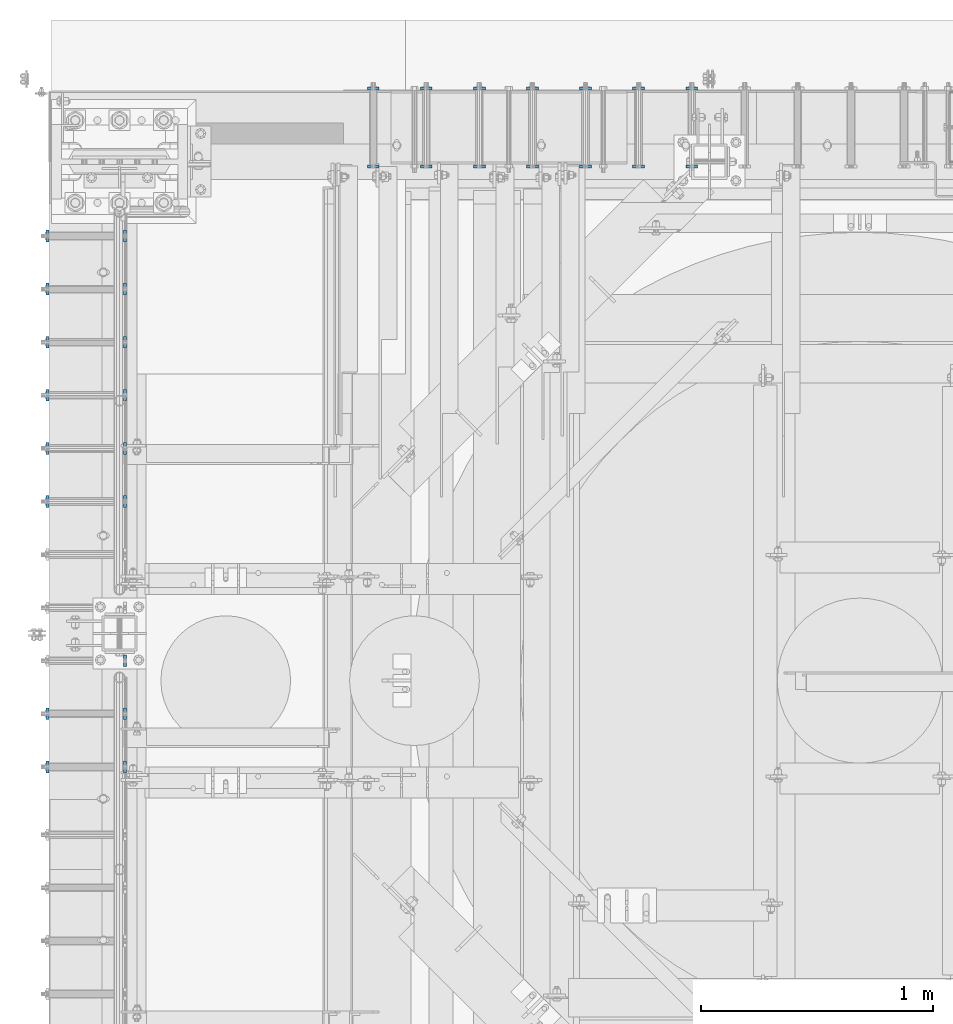
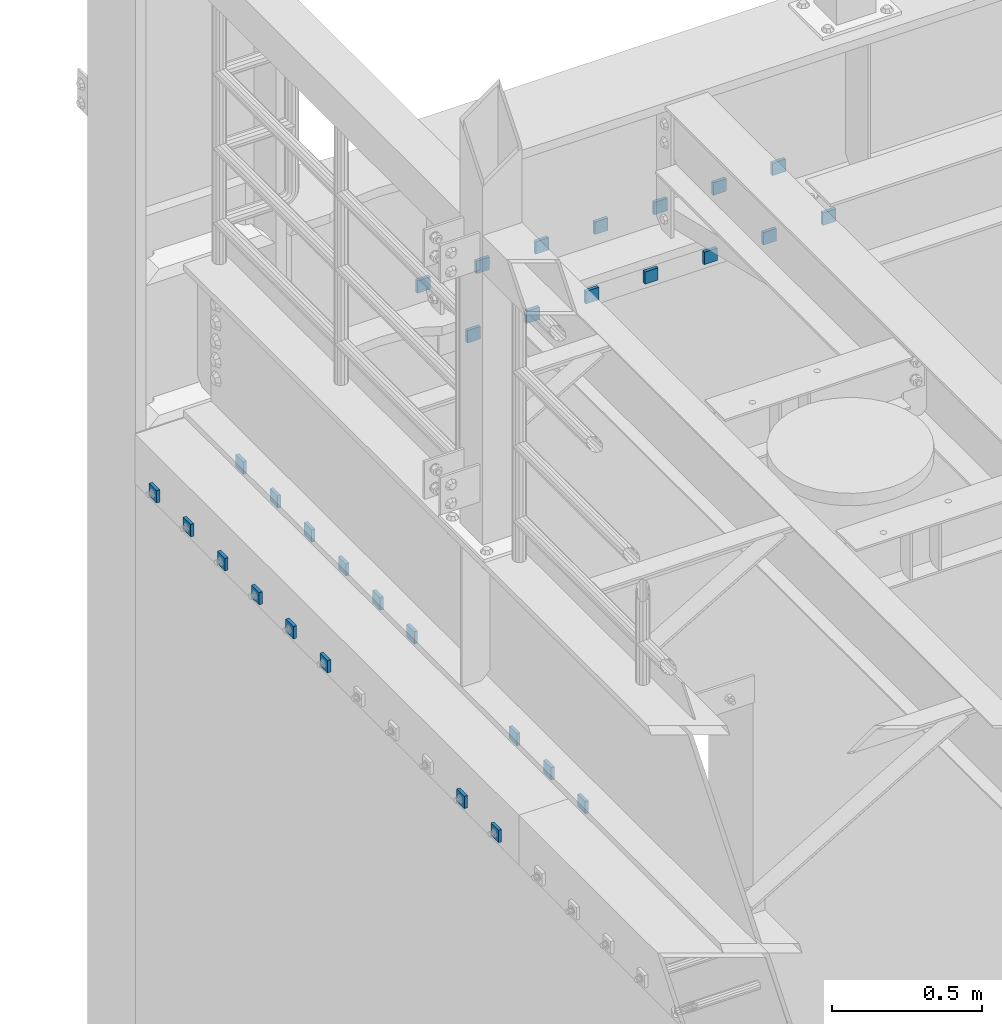
# One storey, part 1843 of 1876: 31 plates, 31 elements without a shape of their own.
"""IFC2X3 building model written with IfcOpenShell, lengths in millimetres."""

from ifc_helpers import new_model, si_unit, frame, origin_with_axes, place, context, subcontext, project, spatial, faceted_brep, material, type_object, element, aggregate, save


model = new_model("IFC2X3")

# Units and contexts
model_context = context("Model", 3, precision=1e-05, world=origin_with_axes())
body_context = subcontext(model_context, "Body", "Model", "MODEL_VIEW")
ifc_project = project(units=[si_unit("LENGTHUNIT", "METRE", prefix="MILLI"), si_unit("AREAUNIT", "SQUARE_METRE"), si_unit("VOLUMEUNIT", "CUBIC_METRE"), si_unit("MASSUNIT", "GRAM", prefix="KILO"), si_unit("TIMEUNIT", "SECOND"), si_unit("PLANEANGLEUNIT", "RADIAN"), si_unit("SOLIDANGLEUNIT", "STERADIAN"), si_unit("THERMODYNAMICTEMPERATUREUNIT", "DEGREE_CELSIUS"), si_unit("LUMINOUSINTENSITYUNIT", "LUMEN")], contexts=[model_context])

# Site, building, storey
site_placement = place(None, origin_with_axes())
site = spatial("IfcSite", under=ifc_project, at=site_placement, CompositionType="ELEMENT")
building_placement = place(site_placement, origin_with_axes())
building = spatial("IfcBuilding", under=site, at=building_placement, Name="Undefined", CompositionType="ELEMENT")
storey_placement = place(building_placement, origin_with_axes())
storey = spatial("IfcBuildingStorey", under=building, at=storey_placement, Name="Undefined", CompositionType="ELEMENT", Elevation=0.0)

# Assembly, plate
assembly_1_placement = place(storey_placement, origin_with_axes())
assembly_1 = element("IfcElementAssembly", 1, at=assembly_1_placement, inside=storey, Name="PLATE_WASHER", AssemblyPlace="NOTDEFINED", PredefinedType="RIGID_FRAME")
ifc_material = material(Name="STEEL/A36")
plate_type = type_object("IfcPlateType", PredefinedType="NOTDEFINED")
plate_1_placement = place(assembly_1_placement, frame((-311.149987792964, 13420.7249980926, 4330.70000610352), z_axis=(0.0, -1.0, 0.0), x_axis=(0.0, 0.0, 1.0)))
plate_1 = element("IfcPlate", 2, at=plate_1_placement, type_object=plate_type, material=ifc_material, Name="PLATE_WASHER", context=body_context, shape_type="Brep", body=[
    faceted_brep([(0.0, -6.35000000000036, 0.0), (-9.09494701772928e-13, -6.35000000000002, 50.7999992370605), (-9.09494701772928e-13, 6.35000000000002, 50.7999992370605), (0.0, 6.35000000000036, 0.0), (50.7999992370605, -6.35000000000002, 50.7999992370605), (50.7999992370605, 6.35000000000002, 50.7999992370605), (50.7999992370605, -6.35000000000002, 0.0), (50.7999992370605, 6.35000000000002, 0.0)], [[[0, 1, 2, 3]], [[1, 4, 5, 2]], [[4, 6, 7, 5]], [[6, 0, 3, 7]], [[5, 7, 3, 2]], [[6, 4, 1, 0]]]),
])
aggregate(assembly_1, [plate_1])

assembly_2_placement = place(storey_placement, origin_with_axes())
assembly_2 = element("IfcElementAssembly", 3, at=assembly_2_placement, inside=storey, Name="PLATE_WASHER", AssemblyPlace="NOTDEFINED", PredefinedType="RIGID_FRAME")
plate_2_placement = place(assembly_2_placement, frame((23.8125000000038, 13420.7249980926, 4330.70000610352), z_axis=(0.0, -1.0, 0.0), x_axis=(0.0, 0.0, 1.0)))
plate_2 = element("IfcPlate", 4, at=plate_2_placement, type_object=plate_type, material=ifc_material, Name="PLATE_WASHER", context=body_context, shape_type="Brep", body=[
    faceted_brep([(0.0, -6.35000000000036, 0.0), (-9.09494701772928e-13, -6.35000000000002, 50.7999992370605), (-9.09494701772928e-13, 6.35000000000002, 50.7999992370605), (0.0, 6.35000000000036, 0.0), (50.7999992370605, -6.35000000000002, 50.7999992370605), (50.7999992370605, 6.35000000000002, 50.7999992370605), (50.7999992370605, -6.35000000000002, 0.0), (50.7999992370605, 6.35000000000002, 0.0)], [[[0, 1, 2, 3]], [[1, 4, 5, 2]], [[4, 6, 7, 5]], [[6, 0, 3, 7]], [[5, 7, 3, 2]], [[6, 4, 1, 0]]]),
])
aggregate(assembly_2, [plate_2])

assembly_3_placement = place(storey_placement, origin_with_axes())
assembly_3 = element("IfcElementAssembly", 5, at=assembly_3_placement, inside=storey, Name="PLATE_WASHER", AssemblyPlace="NOTDEFINED", PredefinedType="RIGID_FRAME")
plate_3_placement = place(assembly_3_placement, frame((-311.149987792964, 13192.1249980926, 4330.70000610352), z_axis=(0.0, -1.0, 0.0), x_axis=(0.0, 0.0, 1.0)))
plate_3 = element("IfcPlate", 6, at=plate_3_placement, type_object=plate_type, material=ifc_material, Name="PLATE_WASHER", context=body_context, shape_type="Brep", body=[
    faceted_brep([(0.0, -6.35000000000036, 0.0), (-9.09494701772928e-13, -6.35000000000002, 50.7999992370605), (-9.09494701772928e-13, 6.35000000000002, 50.7999992370605), (0.0, 6.35000000000036, 0.0), (50.7999992370605, -6.35000000000002, 50.7999992370605), (50.7999992370605, 6.35000000000002, 50.7999992370605), (50.7999992370605, -6.35000000000002, 0.0), (50.7999992370605, 6.35000000000002, 0.0)], [[[0, 1, 2, 3]], [[1, 4, 5, 2]], [[4, 6, 7, 5]], [[6, 0, 3, 7]], [[5, 7, 3, 2]], [[6, 4, 1, 0]]]),
])
aggregate(assembly_3, [plate_3])

assembly_4_placement = place(storey_placement, origin_with_axes())
assembly_4 = element("IfcElementAssembly", 7, at=assembly_4_placement, inside=storey, Name="PLATE_WASHER", AssemblyPlace="NOTDEFINED", PredefinedType="RIGID_FRAME")
plate_4_placement = place(assembly_4_placement, frame((23.8125000000036, 13192.1249980926, 4330.70000610352), z_axis=(0.0, -1.0, 0.0), x_axis=(0.0, 0.0, 1.0)))
plate_4 = element("IfcPlate", 8, at=plate_4_placement, type_object=plate_type, material=ifc_material, Name="PLATE_WASHER", context=body_context, shape_type="Brep", body=[
    faceted_brep([(0.0, -6.35000000000036, 0.0), (-9.09494701772928e-13, -6.35000000000002, 50.7999992370605), (-9.09494701772928e-13, 6.35000000000002, 50.7999992370605), (0.0, 6.35000000000036, 0.0), (50.7999992370605, -6.35000000000002, 50.7999992370605), (50.7999992370605, 6.35000000000002, 50.7999992370605), (50.7999992370605, -6.35000000000002, 0.0), (50.7999992370605, 6.35000000000002, 0.0)], [[[0, 1, 2, 3]], [[1, 4, 5, 2]], [[4, 6, 7, 5]], [[6, 0, 3, 7]], [[5, 7, 3, 2]], [[6, 4, 1, 0]]]),
])
aggregate(assembly_4, [plate_4])

assembly_5_placement = place(storey_placement, origin_with_axes())
assembly_5 = element("IfcElementAssembly", 9, at=assembly_5_placement, inside=storey, Name="PLATE_WASHER", AssemblyPlace="NOTDEFINED", PredefinedType="RIGID_FRAME")
plate_5_placement = place(assembly_5_placement, frame((-311.149987792964, 12963.5249980926, 4330.70000610352), z_axis=(0.0, -1.0, 0.0), x_axis=(0.0, 0.0, 1.0)))
plate_5 = element("IfcPlate", 10, at=plate_5_placement, type_object=plate_type, material=ifc_material, Name="PLATE_WASHER", context=body_context, shape_type="Brep", body=[
    faceted_brep([(0.0, -6.35000000000036, 0.0), (-9.09494701772928e-13, -6.35000000000002, 50.7999992370605), (-9.09494701772928e-13, 6.35000000000002, 50.7999992370605), (0.0, 6.35000000000036, 0.0), (50.7999992370605, -6.35000000000002, 50.7999992370605), (50.7999992370605, 6.35000000000002, 50.7999992370605), (50.7999992370605, -6.35000000000002, 0.0), (50.7999992370605, 6.35000000000002, 0.0)], [[[0, 1, 2, 3]], [[1, 4, 5, 2]], [[4, 6, 7, 5]], [[6, 0, 3, 7]], [[5, 7, 3, 2]], [[6, 4, 1, 0]]]),
])
aggregate(assembly_5, [plate_5])

assembly_6_placement = place(storey_placement, origin_with_axes())
assembly_6 = element("IfcElementAssembly", 11, at=assembly_6_placement, inside=storey, Name="PLATE_WASHER", AssemblyPlace="NOTDEFINED", PredefinedType="RIGID_FRAME")
plate_6_placement = place(assembly_6_placement, frame((23.8125000000035, 12963.5249980926, 4330.70000610352), z_axis=(0.0, -1.0, 0.0), x_axis=(0.0, 0.0, 1.0)))
plate_6 = element("IfcPlate", 12, at=plate_6_placement, type_object=plate_type, material=ifc_material, Name="PLATE_WASHER", context=body_context, shape_type="Brep", body=[
    faceted_brep([(0.0, -6.35000000000036, 0.0), (-9.09494701772928e-13, -6.35000000000002, 50.7999992370605), (-9.09494701772928e-13, 6.35000000000002, 50.7999992370605), (0.0, 6.35000000000036, 0.0), (50.7999992370605, -6.35000000000002, 50.7999992370605), (50.7999992370605, 6.35000000000002, 50.7999992370605), (50.7999992370605, -6.35000000000002, 0.0), (50.7999992370605, 6.35000000000002, 0.0)], [[[0, 1, 2, 3]], [[1, 4, 5, 2]], [[4, 6, 7, 5]], [[6, 0, 3, 7]], [[5, 7, 3, 2]], [[6, 4, 1, 0]]]),
])
aggregate(assembly_6, [plate_6])

assembly_7_placement = place(storey_placement, origin_with_axes())
assembly_7 = element("IfcElementAssembly", 13, at=assembly_7_placement, inside=storey, Name="PLATE_WASHER", AssemblyPlace="NOTDEFINED", PredefinedType="RIGID_FRAME")
plate_7_placement = place(assembly_7_placement, frame((-311.149987792965, 12734.9249980926, 4330.70000610352), z_axis=(0.0, -1.0, 0.0), x_axis=(0.0, 0.0, 1.0)))
plate_7 = element("IfcPlate", 14, at=plate_7_placement, type_object=plate_type, material=ifc_material, Name="PLATE_WASHER", context=body_context, shape_type="Brep", body=[
    faceted_brep([(0.0, -6.35000000000036, 0.0), (-9.09494701772928e-13, -6.35000000000002, 50.7999992370605), (-9.09494701772928e-13, 6.35000000000002, 50.7999992370605), (0.0, 6.35000000000036, 0.0), (50.7999992370605, -6.35000000000002, 50.7999992370605), (50.7999992370605, 6.35000000000002, 50.7999992370605), (50.7999992370605, -6.35000000000002, 0.0), (50.7999992370605, 6.35000000000002, 0.0)], [[[0, 1, 2, 3]], [[1, 4, 5, 2]], [[4, 6, 7, 5]], [[6, 0, 3, 7]], [[5, 7, 3, 2]], [[6, 4, 1, 0]]]),
])
aggregate(assembly_7, [plate_7])

assembly_8_placement = place(storey_placement, origin_with_axes())
assembly_8 = element("IfcElementAssembly", 15, at=assembly_8_placement, inside=storey, Name="PLATE_WASHER", AssemblyPlace="NOTDEFINED", PredefinedType="RIGID_FRAME")
plate_8_placement = place(assembly_8_placement, frame((23.8125000000033, 12734.9249980926, 4330.70000610352), z_axis=(0.0, -1.0, 0.0), x_axis=(0.0, 0.0, 1.0)))
plate_8 = element("IfcPlate", 16, at=plate_8_placement, type_object=plate_type, material=ifc_material, Name="PLATE_WASHER", context=body_context, shape_type="Brep", body=[
    faceted_brep([(0.0, -6.35000000000036, 0.0), (-9.09494701772928e-13, -6.35000000000002, 50.7999992370605), (-9.09494701772928e-13, 6.35000000000002, 50.7999992370605), (0.0, 6.35000000000036, 0.0), (50.7999992370605, -6.35000000000002, 50.7999992370605), (50.7999992370605, 6.35000000000002, 50.7999992370605), (50.7999992370605, -6.35000000000002, 0.0), (50.7999992370605, 6.35000000000002, 0.0)], [[[0, 1, 2, 3]], [[1, 4, 5, 2]], [[4, 6, 7, 5]], [[6, 0, 3, 7]], [[5, 7, 3, 2]], [[6, 4, 1, 0]]]),
])
aggregate(assembly_8, [plate_8])

assembly_9_placement = place(storey_placement, origin_with_axes())
assembly_9 = element("IfcElementAssembly", 17, at=assembly_9_placement, inside=storey, Name="PLATE_WASHER", AssemblyPlace="NOTDEFINED", PredefinedType="RIGID_FRAME")
plate_9_placement = place(assembly_9_placement, frame((-311.149987792965, 12506.3249980926, 4330.70000610352), z_axis=(0.0, -1.0, 0.0), x_axis=(0.0, 0.0, 1.0)))
plate_9 = element("IfcPlate", 18, at=plate_9_placement, type_object=plate_type, material=ifc_material, Name="PLATE_WASHER", context=body_context, shape_type="Brep", body=[
    faceted_brep([(0.0, -6.35000000000036, 0.0), (-9.09494701772928e-13, -6.35000000000002, 50.7999992370605), (-9.09494701772928e-13, 6.35000000000002, 50.7999992370605), (0.0, 6.35000000000036, 0.0), (50.7999992370605, -6.35000000000002, 50.7999992370605), (50.7999992370605, 6.35000000000002, 50.7999992370605), (50.7999992370605, -6.35000000000002, 0.0), (50.7999992370605, 6.35000000000002, 0.0)], [[[0, 1, 2, 3]], [[1, 4, 5, 2]], [[4, 6, 7, 5]], [[6, 0, 3, 7]], [[5, 7, 3, 2]], [[6, 4, 1, 0]]]),
])
aggregate(assembly_9, [plate_9])

assembly_10_placement = place(storey_placement, origin_with_axes())
assembly_10 = element("IfcElementAssembly", 19, at=assembly_10_placement, inside=storey, Name="PLATE_WASHER", AssemblyPlace="NOTDEFINED", PredefinedType="RIGID_FRAME")
plate_10_placement = place(assembly_10_placement, frame((23.8125000000031, 12506.3249980926, 4330.70000610352), z_axis=(0.0, -1.0, 0.0), x_axis=(0.0, 0.0, 1.0)))
plate_10 = element("IfcPlate", 20, at=plate_10_placement, type_object=plate_type, material=ifc_material, Name="PLATE_WASHER", context=body_context, shape_type="Brep", body=[
    faceted_brep([(0.0, -6.35000000000036, 0.0), (-9.09494701772928e-13, -6.35000000000002, 50.7999992370605), (-9.09494701772928e-13, 6.35000000000002, 50.7999992370605), (0.0, 6.35000000000036, 0.0), (50.7999992370605, -6.35000000000002, 50.7999992370605), (50.7999992370605, 6.35000000000002, 50.7999992370605), (50.7999992370605, -6.35000000000002, 0.0), (50.7999992370605, 6.35000000000002, 0.0)], [[[0, 1, 2, 3]], [[1, 4, 5, 2]], [[4, 6, 7, 5]], [[6, 0, 3, 7]], [[5, 7, 3, 2]], [[6, 4, 1, 0]]]),
])
aggregate(assembly_10, [plate_10])

assembly_11_placement = place(storey_placement, origin_with_axes())
assembly_11 = element("IfcElementAssembly", 21, at=assembly_11_placement, inside=storey, Name="PLATE_WASHER", AssemblyPlace="NOTDEFINED", PredefinedType="RIGID_FRAME")
plate_11_placement = place(assembly_11_placement, frame((-311.149987792965, 12277.7249980926, 4330.70000610352), z_axis=(0.0, -1.0, 0.0), x_axis=(0.0, 0.0, 1.0)))
plate_11 = element("IfcPlate", 22, at=plate_11_placement, type_object=plate_type, material=ifc_material, Name="PLATE_WASHER", context=body_context, shape_type="Brep", body=[
    faceted_brep([(0.0, -6.35000000000036, 0.0), (-9.09494701772928e-13, -6.35000000000002, 50.7999992370605), (-9.09494701772928e-13, 6.35000000000002, 50.7999992370605), (0.0, 6.35000000000036, 0.0), (50.7999992370605, -6.35000000000002, 50.7999992370605), (50.7999992370605, 6.35000000000002, 50.7999992370605), (50.7999992370605, -6.35000000000002, 0.0), (50.7999992370605, 6.35000000000002, 0.0)], [[[0, 1, 2, 3]], [[1, 4, 5, 2]], [[4, 6, 7, 5]], [[6, 0, 3, 7]], [[5, 7, 3, 2]], [[6, 4, 1, 0]]]),
])
aggregate(assembly_11, [plate_11])

assembly_12_placement = place(storey_placement, origin_with_axes())
assembly_12 = element("IfcElementAssembly", 23, at=assembly_12_placement, inside=storey, Name="PLATE_WASHER", AssemblyPlace="NOTDEFINED", PredefinedType="RIGID_FRAME")
plate_12_placement = place(assembly_12_placement, frame((23.8125000000029, 12277.7249980926, 4330.70000610352), z_axis=(0.0, -1.0, 0.0), x_axis=(0.0, 0.0, 1.0)))
plate_12 = element("IfcPlate", 24, at=plate_12_placement, type_object=plate_type, material=ifc_material, Name="PLATE_WASHER", context=body_context, shape_type="Brep", body=[
    faceted_brep([(0.0, -6.35000000000036, 0.0), (-9.09494701772928e-13, -6.35000000000002, 50.7999992370605), (-9.09494701772928e-13, 6.35000000000002, 50.7999992370605), (0.0, 6.35000000000036, 0.0), (50.7999992370605, -6.35000000000002, 50.7999992370605), (50.7999992370605, 6.35000000000002, 50.7999992370605), (50.7999992370605, -6.35000000000002, 0.0), (50.7999992370605, 6.35000000000002, 0.0)], [[[0, 1, 2, 3]], [[1, 4, 5, 2]], [[4, 6, 7, 5]], [[6, 0, 3, 7]], [[5, 7, 3, 2]], [[6, 4, 1, 0]]]),
])
aggregate(assembly_12, [plate_12])

assembly_13_placement = place(storey_placement, origin_with_axes())
assembly_13 = element("IfcElementAssembly", 25, at=assembly_13_placement, inside=storey, Name="PLATE_WASHER", AssemblyPlace="NOTDEFINED", PredefinedType="RIGID_FRAME")
plate_13_placement = place(assembly_13_placement, frame((23.8125000000023, 11591.9249980926, 4330.70000610352), z_axis=(0.0, -1.0, 0.0), x_axis=(0.0, 0.0, 1.0)))
plate_13 = element("IfcPlate", 26, at=plate_13_placement, type_object=plate_type, material=ifc_material, Name="PLATE_WASHER", context=body_context, shape_type="Brep", body=[
    faceted_brep([(0.0, -6.35000000000036, 0.0), (-9.09494701772928e-13, -6.35000000000002, 50.7999992370605), (-9.09494701772928e-13, 6.35000000000002, 50.7999992370605), (0.0, 6.35000000000036, 0.0), (50.7999992370605, -6.35000000000002, 50.7999992370605), (50.7999992370605, 6.35000000000002, 50.7999992370605), (50.7999992370605, -6.35000000000002, 0.0), (50.7999992370605, 6.35000000000002, 0.0)], [[[0, 1, 2, 3]], [[1, 4, 5, 2]], [[4, 6, 7, 5]], [[6, 0, 3, 7]], [[5, 7, 3, 2]], [[6, 4, 1, 0]]]),
])
aggregate(assembly_13, [plate_13])

assembly_14_placement = place(storey_placement, origin_with_axes())
assembly_14 = element("IfcElementAssembly", 27, at=assembly_14_placement, inside=storey, Name="PLATE_WASHER", AssemblyPlace="NOTDEFINED", PredefinedType="RIGID_FRAME")
plate_14_placement = place(assembly_14_placement, frame((-311.149987792966, 11363.3249980926, 4330.70000610352), z_axis=(0.0, -1.0, 0.0), x_axis=(0.0, 0.0, 1.0)))
plate_14 = element("IfcPlate", 28, at=plate_14_placement, type_object=plate_type, material=ifc_material, Name="PLATE_WASHER", context=body_context, shape_type="Brep", body=[
    faceted_brep([(0.0, -6.35000000000036, 0.0), (-9.09494701772928e-13, -6.35000000000002, 50.7999992370605), (-9.09494701772928e-13, 6.35000000000002, 50.7999992370605), (0.0, 6.35000000000036, 0.0), (50.7999992370605, -6.35000000000002, 50.7999992370605), (50.7999992370605, 6.35000000000002, 50.7999992370605), (50.7999992370605, -6.35000000000002, 0.0), (50.7999992370605, 6.35000000000002, 0.0)], [[[0, 1, 2, 3]], [[1, 4, 5, 2]], [[4, 6, 7, 5]], [[6, 0, 3, 7]], [[5, 7, 3, 2]], [[6, 4, 1, 0]]]),
])
aggregate(assembly_14, [plate_14])

assembly_15_placement = place(storey_placement, origin_with_axes())
assembly_15 = element("IfcElementAssembly", 29, at=assembly_15_placement, inside=storey, Name="PLATE_WASHER", AssemblyPlace="NOTDEFINED", PredefinedType="RIGID_FRAME")
plate_15_placement = place(assembly_15_placement, frame((23.8125000000022, 11363.3249980926, 4330.70000610352), z_axis=(0.0, -1.0, 0.0), x_axis=(0.0, 0.0, 1.0)))
plate_15 = element("IfcPlate", 30, at=plate_15_placement, type_object=plate_type, material=ifc_material, Name="PLATE_WASHER", context=body_context, shape_type="Brep", body=[
    faceted_brep([(0.0, -6.35000000000036, 0.0), (-9.09494701772928e-13, -6.35000000000002, 50.7999992370605), (-9.09494701772928e-13, 6.35000000000002, 50.7999992370605), (0.0, 6.35000000000036, 0.0), (50.7999992370605, -6.35000000000002, 50.7999992370605), (50.7999992370605, 6.35000000000002, 50.7999992370605), (50.7999992370605, -6.35000000000002, 0.0), (50.7999992370605, 6.35000000000002, 0.0)], [[[0, 1, 2, 3]], [[1, 4, 5, 2]], [[4, 6, 7, 5]], [[6, 0, 3, 7]], [[5, 7, 3, 2]], [[6, 4, 1, 0]]]),
])
aggregate(assembly_15, [plate_15])

assembly_16_placement = place(storey_placement, origin_with_axes())
assembly_16 = element("IfcElementAssembly", 31, at=assembly_16_placement, inside=storey, Name="PLATE_WASHER", AssemblyPlace="NOTDEFINED", PredefinedType="RIGID_FRAME")
plate_16_placement = place(assembly_16_placement, frame((-311.149987792966, 11134.7249980926, 4330.70000610352), z_axis=(0.0, -1.0, 0.0), x_axis=(0.0, 0.0, 1.0)))
plate_16 = element("IfcPlate", 32, at=plate_16_placement, type_object=plate_type, material=ifc_material, Name="PLATE_WASHER", context=body_context, shape_type="Brep", body=[
    faceted_brep([(0.0, -6.35000000000036, 0.0), (-9.09494701772928e-13, -6.35000000000002, 50.7999992370605), (-9.09494701772928e-13, 6.35000000000002, 50.7999992370605), (0.0, 6.35000000000036, 0.0), (50.7999992370605, -6.35000000000002, 50.7999992370605), (50.7999992370605, 6.35000000000002, 50.7999992370605), (50.7999992370605, -6.35000000000002, 0.0), (50.7999992370605, 6.35000000000002, 0.0)], [[[0, 1, 2, 3]], [[1, 4, 5, 2]], [[4, 6, 7, 5]], [[6, 0, 3, 7]], [[5, 7, 3, 2]], [[6, 4, 1, 0]]]),
])
aggregate(assembly_16, [plate_16])

assembly_17_placement = place(storey_placement, origin_with_axes())
assembly_17 = element("IfcElementAssembly", 33, at=assembly_17_placement, inside=storey, Name="PLATE_WASHER", AssemblyPlace="NOTDEFINED", PredefinedType="RIGID_FRAME")
plate_17_placement = place(assembly_17_placement, frame((23.812500000002, 11134.7249980926, 4330.70000610352), z_axis=(0.0, -1.0, 0.0), x_axis=(0.0, 0.0, 1.0)))
plate_17 = element("IfcPlate", 34, at=plate_17_placement, type_object=plate_type, material=ifc_material, Name="PLATE_WASHER", context=body_context, shape_type="Brep", body=[
    faceted_brep([(0.0, -6.35000000000036, 0.0), (-9.09494701772928e-13, -6.35000000000002, 50.7999992370605), (-9.09494701772928e-13, 6.35000000000002, 50.7999992370605), (0.0, 6.35000000000036, 0.0), (50.7999992370605, -6.35000000000002, 50.7999992370605), (50.7999992370605, 6.35000000000002, 50.7999992370605), (50.7999992370605, -6.35000000000002, 0.0), (50.7999992370605, 6.35000000000002, 0.0)], [[[0, 1, 2, 3]], [[1, 4, 5, 2]], [[4, 6, 7, 5]], [[6, 0, 3, 7]], [[5, 7, 3, 2]], [[6, 4, 1, 0]]]),
])
aggregate(assembly_17, [plate_17])

assembly_18_placement = place(storey_placement, origin_with_axes())
assembly_18 = element("IfcElementAssembly", 35, at=assembly_18_placement, inside=storey, Name="PLATE_WASHER", AssemblyPlace="NOTDEFINED", PredefinedType="RIGID_FRAME")
plate_18_placement = place(assembly_18_placement, frame((2489.20001182556, 14030.325, 4305.30000610352), z_axis=(-1.0, 0.0, 0.0), x_axis=(0.0, 0.0, 1.0)))
plate_18 = element("IfcPlate", 36, at=plate_18_placement, type_object=plate_type, material=ifc_material, Name="PLATE_WASHER", context=body_context, shape_type="Brep", body=[
    faceted_brep([(0.0, -6.35000000000036, 0.0), (-9.09494701772928e-13, -6.35000000000002, 50.7999992370605), (-9.09494701772928e-13, 6.35000000000002, 50.7999992370605), (0.0, 6.35000000000036, 0.0), (50.7999992370605, -6.35000000000002, 50.7999992370605), (50.7999992370605, 6.35000000000002, 50.7999992370605), (50.7999992370605, -6.35000000000002, 0.0), (50.7999992370605, 6.35000000000002, 0.0)], [[[0, 1, 2, 3]], [[1, 4, 5, 2]], [[4, 6, 7, 5]], [[6, 0, 3, 7]], [[5, 7, 3, 2]], [[6, 4, 1, 0]]]),
])
aggregate(assembly_18, [plate_18])

assembly_19_placement = place(storey_placement, origin_with_axes())
assembly_19 = element("IfcElementAssembly", 37, at=assembly_19_placement, inside=storey, Name="PLATE_WASHER", AssemblyPlace="NOTDEFINED", PredefinedType="RIGID_FRAME")
plate_19_placement = place(assembly_19_placement, frame((2489.20001182556, 13695.362512207, 4305.30000610352), z_axis=(-1.0, 0.0, 0.0), x_axis=(0.0, 0.0, 1.0)))
plate_19 = element("IfcPlate", 38, at=plate_19_placement, type_object=plate_type, material=ifc_material, Name="PLATE_WASHER", context=body_context, shape_type="Brep", body=[
    faceted_brep([(0.0, -6.35000000000036, 0.0), (-9.09494701772928e-13, -6.35000000000002, 50.7999992370605), (-9.09494701772928e-13, 6.35000000000002, 50.7999992370605), (0.0, 6.35000000000036, 0.0), (50.7999992370605, -6.35000000000002, 50.7999992370605), (50.7999992370605, 6.35000000000002, 50.7999992370605), (50.7999992370605, -6.35000000000002, 0.0), (50.7999992370605, 6.35000000000002, 0.0)], [[[0, 1, 2, 3]], [[1, 4, 5, 2]], [[4, 6, 7, 5]], [[6, 0, 3, 7]], [[5, 7, 3, 2]], [[6, 4, 1, 0]]]),
])
aggregate(assembly_19, [plate_19])

assembly_20_placement = place(storey_placement, origin_with_axes())
assembly_20 = element("IfcElementAssembly", 39, at=assembly_20_placement, inside=storey, Name="PLATE_WASHER", AssemblyPlace="NOTDEFINED", PredefinedType="RIGID_FRAME")
plate_20_placement = place(assembly_20_placement, frame((2260.60001182556, 14030.325, 4305.30000610352), z_axis=(-1.0, 0.0, 0.0), x_axis=(0.0, 0.0, 1.0)))
plate_20 = element("IfcPlate", 40, at=plate_20_placement, type_object=plate_type, material=ifc_material, Name="PLATE_WASHER", context=body_context, shape_type="Brep", body=[
    faceted_brep([(0.0, -6.35000000000036, 0.0), (-9.09494701772928e-13, -6.35000000000002, 50.7999992370605), (-9.09494701772928e-13, 6.35000000000002, 50.7999992370605), (0.0, 6.35000000000036, 0.0), (50.7999992370605, -6.35000000000002, 50.7999992370605), (50.7999992370605, 6.35000000000002, 50.7999992370605), (50.7999992370605, -6.35000000000002, 0.0), (50.7999992370605, 6.35000000000002, 0.0)], [[[0, 1, 2, 3]], [[1, 4, 5, 2]], [[4, 6, 7, 5]], [[6, 0, 3, 7]], [[5, 7, 3, 2]], [[6, 4, 1, 0]]]),
])
aggregate(assembly_20, [plate_20])

assembly_21_placement = place(storey_placement, origin_with_axes())
assembly_21 = element("IfcElementAssembly", 41, at=assembly_21_placement, inside=storey, Name="PLATE_WASHER", AssemblyPlace="NOTDEFINED", PredefinedType="RIGID_FRAME")
plate_21_placement = place(assembly_21_placement, frame((2260.60001182556, 13695.362512207, 4305.30000610352), z_axis=(-1.0, 0.0, 0.0), x_axis=(0.0, 0.0, 1.0)))
plate_21 = element("IfcPlate", 42, at=plate_21_placement, type_object=plate_type, material=ifc_material, Name="PLATE_WASHER", context=body_context, shape_type="Brep", body=[
    faceted_brep([(0.0, -6.35000000000036, 0.0), (-9.09494701772928e-13, -6.35000000000002, 50.7999992370605), (-9.09494701772928e-13, 6.35000000000002, 50.7999992370605), (0.0, 6.35000000000036, 0.0), (50.7999992370605, -6.35000000000002, 50.7999992370605), (50.7999992370605, 6.35000000000002, 50.7999992370605), (50.7999992370605, -6.35000000000002, 0.0), (50.7999992370605, 6.35000000000002, 0.0)], [[[0, 1, 2, 3]], [[1, 4, 5, 2]], [[4, 6, 7, 5]], [[6, 0, 3, 7]], [[5, 7, 3, 2]], [[6, 4, 1, 0]]]),
])
aggregate(assembly_21, [plate_21])

assembly_22_placement = place(storey_placement, origin_with_axes())
assembly_22 = element("IfcElementAssembly", 43, at=assembly_22_placement, inside=storey, Name="PLATE_WASHER", AssemblyPlace="NOTDEFINED", PredefinedType="RIGID_FRAME")
plate_22_placement = place(assembly_22_placement, frame((2032.00001182556, 14030.325, 4305.30000610352), z_axis=(-1.0, 0.0, 0.0), x_axis=(0.0, 0.0, 1.0)))
plate_22 = element("IfcPlate", 44, at=plate_22_placement, type_object=plate_type, material=ifc_material, Name="PLATE_WASHER", context=body_context, shape_type="Brep", body=[
    faceted_brep([(0.0, -6.35000000000036, 0.0), (-9.09494701772928e-13, -6.35000000000002, 50.7999992370605), (-9.09494701772928e-13, 6.35000000000002, 50.7999992370605), (0.0, 6.35000000000036, 0.0), (50.7999992370605, -6.35000000000002, 50.7999992370605), (50.7999992370605, 6.35000000000002, 50.7999992370605), (50.7999992370605, -6.35000000000002, 0.0), (50.7999992370605, 6.35000000000002, 0.0)], [[[0, 1, 2, 3]], [[1, 4, 5, 2]], [[4, 6, 7, 5]], [[6, 0, 3, 7]], [[5, 7, 3, 2]], [[6, 4, 1, 0]]]),
])
aggregate(assembly_22, [plate_22])

assembly_23_placement = place(storey_placement, origin_with_axes())
assembly_23 = element("IfcElementAssembly", 45, at=assembly_23_placement, inside=storey, Name="PLATE_WASHER", AssemblyPlace="NOTDEFINED", PredefinedType="RIGID_FRAME")
plate_23_placement = place(assembly_23_placement, frame((2032.00001182556, 13695.362512207, 4305.30000610352), z_axis=(-1.0, 0.0, 0.0), x_axis=(0.0, 0.0, 1.0)))
plate_23 = element("IfcPlate", 46, at=plate_23_placement, type_object=plate_type, material=ifc_material, Name="PLATE_WASHER", context=body_context, shape_type="Brep", body=[
    faceted_brep([(0.0, -6.35000000000036, 0.0), (-9.09494701772928e-13, -6.35000000000002, 50.7999992370605), (-9.09494701772928e-13, 6.35000000000002, 50.7999992370605), (0.0, 6.35000000000036, 0.0), (50.7999992370605, -6.35000000000002, 50.7999992370605), (50.7999992370605, 6.35000000000002, 50.7999992370605), (50.7999992370605, -6.35000000000002, 0.0), (50.7999992370605, 6.35000000000002, 0.0)], [[[0, 1, 2, 3]], [[1, 4, 5, 2]], [[4, 6, 7, 5]], [[6, 0, 3, 7]], [[5, 7, 3, 2]], [[6, 4, 1, 0]]]),
])
aggregate(assembly_23, [plate_23])

assembly_24_placement = place(storey_placement, origin_with_axes())
assembly_24 = element("IfcElementAssembly", 47, at=assembly_24_placement, inside=storey, Name="PLATE_WASHER", AssemblyPlace="NOTDEFINED", PredefinedType="RIGID_FRAME")
plate_24_placement = place(assembly_24_placement, frame((1803.40001182556, 14030.325, 4305.30000610352), z_axis=(-1.0, 0.0, 0.0), x_axis=(0.0, 0.0, 1.0)))
plate_24 = element("IfcPlate", 48, at=plate_24_placement, type_object=plate_type, material=ifc_material, Name="PLATE_WASHER", context=body_context, shape_type="Brep", body=[
    faceted_brep([(0.0, -6.35000000000036, 0.0), (-9.09494701772928e-13, -6.35000000000002, 50.7999992370605), (-9.09494701772928e-13, 6.35000000000002, 50.7999992370605), (0.0, 6.35000000000036, 0.0), (50.7999992370605, -6.35000000000002, 50.7999992370605), (50.7999992370605, 6.35000000000002, 50.7999992370605), (50.7999992370605, -6.35000000000002, 0.0), (50.7999992370605, 6.35000000000002, 0.0)], [[[0, 1, 2, 3]], [[1, 4, 5, 2]], [[4, 6, 7, 5]], [[6, 0, 3, 7]], [[5, 7, 3, 2]], [[6, 4, 1, 0]]]),
])
aggregate(assembly_24, [plate_24])

assembly_25_placement = place(storey_placement, origin_with_axes())
assembly_25 = element("IfcElementAssembly", 49, at=assembly_25_placement, inside=storey, Name="PLATE_WASHER", AssemblyPlace="NOTDEFINED", PredefinedType="RIGID_FRAME")
plate_25_placement = place(assembly_25_placement, frame((1803.40001182556, 13695.362512207, 4305.30000610352), z_axis=(-1.0, 0.0, 0.0), x_axis=(0.0, 0.0, 1.0)))
plate_25 = element("IfcPlate", 50, at=plate_25_placement, type_object=plate_type, material=ifc_material, Name="PLATE_WASHER", context=body_context, shape_type="Brep", body=[
    faceted_brep([(0.0, -6.35000000000036, 0.0), (-9.09494701772928e-13, -6.35000000000002, 50.7999992370605), (-9.09494701772928e-13, 6.35000000000002, 50.7999992370605), (0.0, 6.35000000000036, 0.0), (50.7999992370605, -6.35000000000002, 50.7999992370605), (50.7999992370605, 6.35000000000002, 50.7999992370605), (50.7999992370605, -6.35000000000002, 0.0), (50.7999992370605, 6.35000000000002, 0.0)], [[[0, 1, 2, 3]], [[1, 4, 5, 2]], [[4, 6, 7, 5]], [[6, 0, 3, 7]], [[5, 7, 3, 2]], [[6, 4, 1, 0]]]),
])
aggregate(assembly_25, [plate_25])

assembly_26_placement = place(storey_placement, origin_with_axes())
assembly_26 = element("IfcElementAssembly", 51, at=assembly_26_placement, inside=storey, Name="PLATE_WASHER", AssemblyPlace="NOTDEFINED", PredefinedType="RIGID_FRAME")
plate_26_placement = place(assembly_26_placement, frame((1574.80001182556, 14030.325, 4305.30000610352), z_axis=(-1.0, 0.0, 0.0), x_axis=(0.0, 0.0, 1.0)))
plate_26 = element("IfcPlate", 52, at=plate_26_placement, type_object=plate_type, material=ifc_material, Name="PLATE_WASHER", context=body_context, shape_type="Brep", body=[
    faceted_brep([(0.0, -6.35000000000036, 0.0), (-9.09494701772928e-13, -6.35000000000002, 50.7999992370605), (-9.09494701772928e-13, 6.35000000000002, 50.7999992370605), (0.0, 6.35000000000036, 0.0), (50.7999992370605, -6.35000000000002, 50.7999992370605), (50.7999992370605, 6.35000000000002, 50.7999992370605), (50.7999992370605, -6.35000000000002, 0.0), (50.7999992370605, 6.35000000000002, 0.0)], [[[0, 1, 2, 3]], [[1, 4, 5, 2]], [[4, 6, 7, 5]], [[6, 0, 3, 7]], [[5, 7, 3, 2]], [[6, 4, 1, 0]]]),
])
aggregate(assembly_26, [plate_26])

assembly_27_placement = place(storey_placement, origin_with_axes())
assembly_27 = element("IfcElementAssembly", 53, at=assembly_27_placement, inside=storey, Name="PLATE_WASHER", AssemblyPlace="NOTDEFINED", PredefinedType="RIGID_FRAME")
plate_27_placement = place(assembly_27_placement, frame((1574.80001182556, 13695.362512207, 4305.30000610352), z_axis=(-1.0, 0.0, 0.0), x_axis=(0.0, 0.0, 1.0)))
plate_27 = element("IfcPlate", 54, at=plate_27_placement, type_object=plate_type, material=ifc_material, Name="PLATE_WASHER", context=body_context, shape_type="Brep", body=[
    faceted_brep([(0.0, -6.35000000000036, 0.0), (-9.09494701772928e-13, -6.35000000000002, 50.7999992370605), (-9.09494701772928e-13, 6.35000000000002, 50.7999992370605), (0.0, 6.35000000000036, 0.0), (50.7999992370605, -6.35000000000002, 50.7999992370605), (50.7999992370605, 6.35000000000002, 50.7999992370605), (50.7999992370605, -6.35000000000002, 0.0), (50.7999992370605, 6.35000000000002, 0.0)], [[[0, 1, 2, 3]], [[1, 4, 5, 2]], [[4, 6, 7, 5]], [[6, 0, 3, 7]], [[5, 7, 3, 2]], [[6, 4, 1, 0]]]),
])
aggregate(assembly_27, [plate_27])

assembly_28_placement = place(storey_placement, origin_with_axes())
assembly_28 = element("IfcElementAssembly", 55, at=assembly_28_placement, inside=storey, Name="PLATE_WASHER", AssemblyPlace="NOTDEFINED", PredefinedType="RIGID_FRAME")
plate_28_placement = place(assembly_28_placement, frame((1346.20001182556, 14030.325, 4305.30000610352), z_axis=(-1.0, 0.0, 0.0), x_axis=(0.0, 0.0, 1.0)))
plate_28 = element("IfcPlate", 56, at=plate_28_placement, type_object=plate_type, material=ifc_material, Name="PLATE_WASHER", context=body_context, shape_type="Brep", body=[
    faceted_brep([(0.0, -6.35000000000036, 0.0), (-9.09494701772928e-13, -6.35000000000002, 50.7999992370605), (-9.09494701772928e-13, 6.35000000000002, 50.7999992370605), (0.0, 6.35000000000036, 0.0), (50.7999992370605, -6.35000000000002, 50.7999992370605), (50.7999992370605, 6.35000000000002, 50.7999992370605), (50.7999992370605, -6.35000000000002, 0.0), (50.7999992370605, 6.35000000000002, 0.0)], [[[0, 1, 2, 3]], [[1, 4, 5, 2]], [[4, 6, 7, 5]], [[6, 0, 3, 7]], [[5, 7, 3, 2]], [[6, 4, 1, 0]]]),
])
aggregate(assembly_28, [plate_28])

assembly_29_placement = place(storey_placement, origin_with_axes())
assembly_29 = element("IfcElementAssembly", 57, at=assembly_29_placement, inside=storey, Name="PLATE_WASHER", AssemblyPlace="NOTDEFINED", PredefinedType="RIGID_FRAME")
plate_29_placement = place(assembly_29_placement, frame((1346.20001182556, 13695.362512207, 4305.30000610352), z_axis=(-1.0, 0.0, 0.0), x_axis=(0.0, 0.0, 1.0)))
plate_29 = element("IfcPlate", 58, at=plate_29_placement, type_object=plate_type, material=ifc_material, Name="PLATE_WASHER", context=body_context, shape_type="Brep", body=[
    faceted_brep([(0.0, -6.35000000000036, 0.0), (-9.09494701772928e-13, -6.35000000000002, 50.7999992370605), (-9.09494701772928e-13, 6.35000000000002, 50.7999992370605), (0.0, 6.35000000000036, 0.0), (50.7999992370605, -6.35000000000002, 50.7999992370605), (50.7999992370605, 6.35000000000002, 50.7999992370605), (50.7999992370605, -6.35000000000002, 0.0), (50.7999992370605, 6.35000000000002, 0.0)], [[[0, 1, 2, 3]], [[1, 4, 5, 2]], [[4, 6, 7, 5]], [[6, 0, 3, 7]], [[5, 7, 3, 2]], [[6, 4, 1, 0]]]),
])
aggregate(assembly_29, [plate_29])

assembly_30_placement = place(storey_placement, origin_with_axes())
assembly_30 = element("IfcElementAssembly", 59, at=assembly_30_placement, inside=storey, Name="PLATE_WASHER", AssemblyPlace="NOTDEFINED", PredefinedType="RIGID_FRAME")
plate_30_placement = place(assembly_30_placement, frame((1117.60001182556, 14030.325, 4305.30000610352), z_axis=(-1.0, 0.0, 0.0), x_axis=(0.0, 0.0, 1.0)))
plate_30 = element("IfcPlate", 60, at=plate_30_placement, type_object=plate_type, material=ifc_material, Name="PLATE_WASHER", context=body_context, shape_type="Brep", body=[
    faceted_brep([(0.0, -6.35000000000036, 0.0), (-9.09494701772928e-13, -6.35000000000002, 50.7999992370605), (-9.09494701772928e-13, 6.35000000000002, 50.7999992370605), (0.0, 6.35000000000036, 0.0), (50.7999992370605, -6.35000000000002, 50.7999992370605), (50.7999992370605, 6.35000000000002, 50.7999992370605), (50.7999992370605, -6.35000000000002, 0.0), (50.7999992370605, 6.35000000000002, 0.0)], [[[0, 1, 2, 3]], [[1, 4, 5, 2]], [[4, 6, 7, 5]], [[6, 0, 3, 7]], [[5, 7, 3, 2]], [[6, 4, 1, 0]]]),
])
aggregate(assembly_30, [plate_30])

assembly_31_placement = place(storey_placement, origin_with_axes())
assembly_31 = element("IfcElementAssembly", 61, at=assembly_31_placement, inside=storey, Name="PLATE_WASHER", AssemblyPlace="NOTDEFINED", PredefinedType="RIGID_FRAME")
plate_31_placement = place(assembly_31_placement, frame((1117.60001182556, 13695.362512207, 4305.30000610352), z_axis=(-1.0, 0.0, 0.0), x_axis=(0.0, 0.0, 1.0)))
plate_31 = element("IfcPlate", 62, at=plate_31_placement, type_object=plate_type, material=ifc_material, Name="PLATE_WASHER", context=body_context, shape_type="Brep", body=[
    faceted_brep([(0.0, -6.35000000000036, 0.0), (-9.09494701772928e-13, -6.35000000000002, 50.7999992370605), (-9.09494701772928e-13, 6.35000000000002, 50.7999992370605), (0.0, 6.35000000000036, 0.0), (50.7999992370605, -6.35000000000002, 50.7999992370605), (50.7999992370605, 6.35000000000002, 50.7999992370605), (50.7999992370605, -6.35000000000002, 0.0), (50.7999992370605, 6.35000000000002, 0.0)], [[[0, 1, 2, 3]], [[1, 4, 5, 2]], [[4, 6, 7, 5]], [[6, 0, 3, 7]], [[5, 7, 3, 2]], [[6, 4, 1, 0]]]),
])
aggregate(assembly_31, [plate_31])

save(model, "model.ifc")
